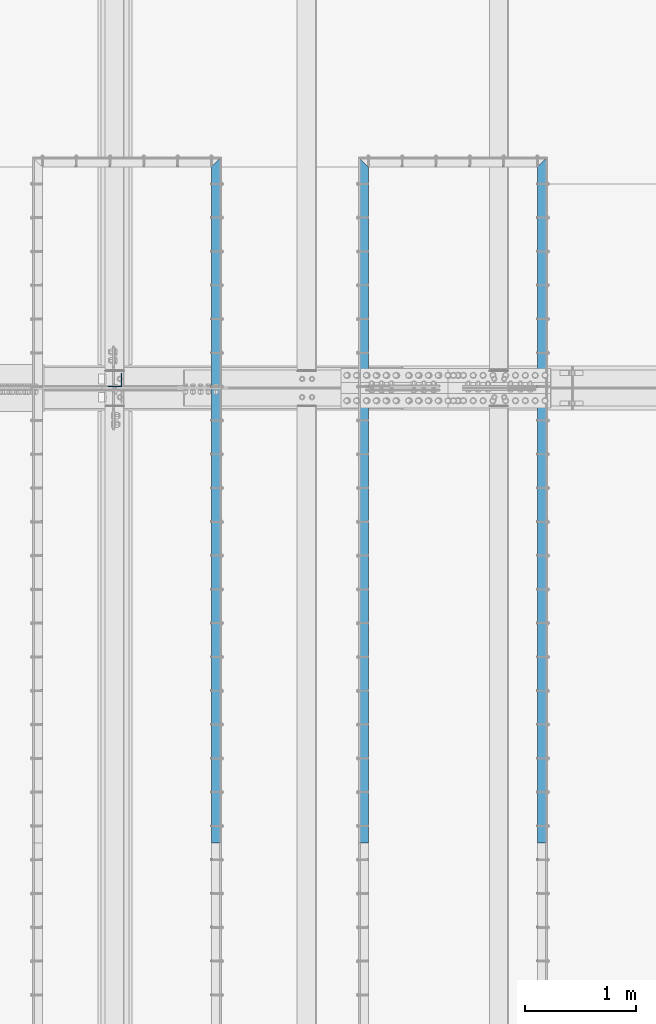
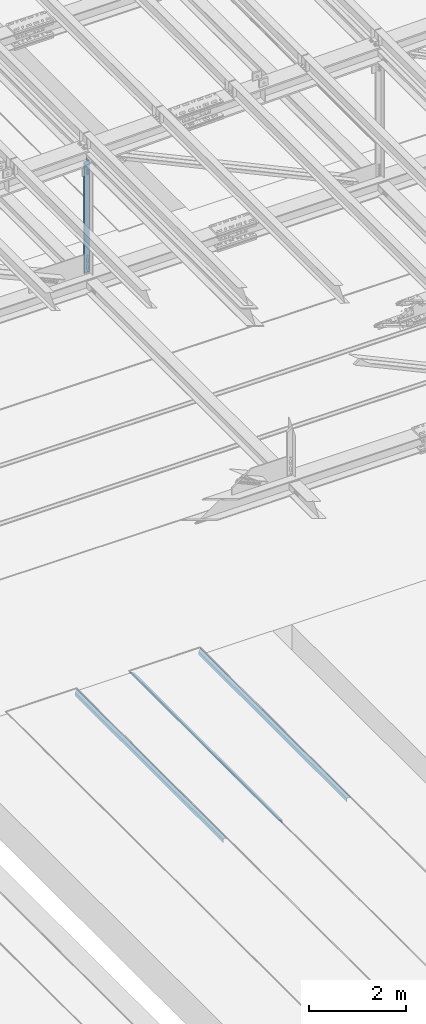
# One storey, part 1843 of 3843: 4 beams, 4 elements without a shape of their own.
"""IFC2X3 building model written with IfcOpenShell, lengths in millimetres."""

from ifc_helpers import new_model, si_unit, frame, origin_with_axes, place, context, subcontext, project, spatial, faceted_brep, material, type_object, element, aggregate, save


model = new_model("IFC2X3")

# Units and contexts
model_context = context("Model", 3, precision=1e-05, world=origin_with_axes())
body_context = subcontext(model_context, "Body", "Model", "MODEL_VIEW")
ifc_project = project(units=[si_unit("LENGTHUNIT", "METRE", prefix="MILLI"), si_unit("AREAUNIT", "SQUARE_METRE"), si_unit("VOLUMEUNIT", "CUBIC_METRE"), si_unit("MASSUNIT", "GRAM", prefix="KILO"), si_unit("TIMEUNIT", "SECOND"), si_unit("PLANEANGLEUNIT", "RADIAN"), si_unit("SOLIDANGLEUNIT", "STERADIAN"), si_unit("THERMODYNAMICTEMPERATUREUNIT", "DEGREE_CELSIUS"), si_unit("LUMINOUSINTENSITYUNIT", "LUMEN")], contexts=[model_context])

# Site, building, storey
site_placement = place(None, origin_with_axes())
site = spatial("IfcSite", under=ifc_project, at=site_placement, CompositionType="ELEMENT")
building_placement = place(site_placement, origin_with_axes())
building = spatial("IfcBuilding", under=site, at=building_placement, Name="Undefined", CompositionType="ELEMENT")
storey_placement = place(building_placement, origin_with_axes())
storey = spatial("IfcBuildingStorey", under=building, at=storey_placement, Name="Undefined", CompositionType="ELEMENT", Elevation=0.0)

# Assembly, beam
assembly_1_placement = place(storey_placement, origin_with_axes())
assembly_1 = element("IfcElementAssembly", 1, at=assembly_1_placement, inside=storey, Name="EMBED_ANGLE", AssemblyPlace="NOTDEFINED", PredefinedType="RIGID_FRAME")
ifc_material_1 = material(Name="STEEL/A36")
beam_type_1 = type_object("IfcBeamType", Name="L3-1/2X3-1/2X5/16", PredefinedType="NOTDEFINED")
beam_1_placement = place(assembly_1_placement, frame((52851.7485419922, 52641.499609375, 30410.15), z_axis=(0.0, 0.0, -1.0), x_axis=(0.0, -1.0, 0.0)))
beam_1 = element("IfcBeam", 2, at=beam_1_placement, type_object=beam_type_1, material=ifc_material_1, Name="EMBED_ANGLE", ObjectType="L3-1/2X3-1/2X5/16", context=body_context, shape_type="Brep", body=[
    faceted_brep([(88.9005548157729, 44.4499999999971, -44.4500000000007), (88.9005548157729, 44.4499999999971, 44.4500000000007), (6184.90000000001, 44.4499999999971, 44.4500000000007), (6184.90000000001, 44.4499999999971, -44.4500000000007), (80.9630575435294, 36.5124999999971, 44.4500000000007), (6184.90000000001, 36.5124999999971, 44.4500000000007), (80.9630575435294, 36.5124999999971, -36.5125000000007), (6184.90000000001, 36.5124999999971, -36.5125000000007), (0.00058536660799291, -44.4499999999971, -36.5125000000007), (6184.89999999999, -44.4499999999971, -36.5125000000007), (0.00058536660799291, -44.4499999999971, -44.4500000000007), (6184.89999999999, -44.4499999999971, -44.4500000000007)], [[[0, 1, 2, 3]], [[1, 4, 5, 2]], [[4, 6, 7, 5]], [[6, 8, 9, 7]], [[8, 10, 11, 9]], [[10, 0, 3, 11]], [[5, 7, 9, 11, 3, 2]], [[10, 8, 6, 4, 1, 0]]]),
])
aggregate(assembly_1, [beam_1])

assembly_2_placement = place(storey_placement, origin_with_axes())
assembly_2 = element("IfcElementAssembly", 3, at=assembly_2_placement, inside=storey, Name="EMBED_ANGLE", AssemblyPlace="NOTDEFINED", PredefinedType="RIGID_FRAME")
beam_2_placement = place(assembly_2_placement, frame((51238.911984375, 46456.599609375, 30410.15), z_axis=(0.0, 0.0, -1.0), x_axis=(0.0, 1.0, 0.0)))
beam_2 = element("IfcBeam", 4, at=beam_2_placement, type_object=beam_type_1, material=ifc_material_1, Name="EMBED_ANGLE", ObjectType="L3-1/2X3-1/2X5/16", context=body_context, shape_type="Brep", body=[
    faceted_brep([(-3.63797880709171e-12, 44.4499999999971, -44.4500000000007), (-3.63797880709171e-12, 44.4499999999971, 44.4500000000007), (6096.0, 44.4499999999971, 44.4500000000007), (6096.0, 44.4499999999971, -44.4500000000007), (-3.63797880709171e-12, 36.5124999999971, 44.4500000000007), (6103.9375, 36.5124999999971, 44.4500000000007), (-3.63797880709171e-12, 36.5124999999971, -36.5125000000007), (6103.9375, 36.5124999999971, -36.5125000000007), (3.63797880709171e-12, -44.4499999999971, -36.5125000000007), (6184.89999999999, -44.4499999999971, -36.5125000000007), (3.63797880709171e-12, -44.4499999999971, -44.4500000000007), (6184.89999999999, -44.4499999999971, -44.4500000000007)], [[[0, 1, 2, 3]], [[1, 4, 5, 2]], [[4, 6, 7, 5]], [[6, 8, 9, 7]], [[8, 10, 11, 9]], [[10, 0, 3, 11]], [[5, 7, 9, 11, 3, 2]], [[10, 8, 6, 4, 1, 0]]]),
])
aggregate(assembly_2, [beam_2])

assembly_3_placement = place(storey_placement, origin_with_axes())
assembly_3 = element("IfcElementAssembly", 5, at=assembly_3_placement, inside=storey, Name="EMBED_ANGLE", AssemblyPlace="NOTDEFINED", PredefinedType="RIGID_FRAME")
beam_3_placement = place(assembly_3_placement, frame((49911.7620881988, 52641.4996235989, 30410.15), z_axis=(0.0, 0.0, -1.0), x_axis=(0.0, -1.0, 0.0)))
beam_3 = element("IfcBeam", 6, at=beam_3_placement, type_object=beam_type_1, material=ifc_material_1, Name="EMBED_ANGLE", ObjectType="L3-1/2X3-1/2X5/16", context=body_context, shape_type="Brep", body=[
    faceted_brep([(88.8999999971129, 44.4500000000007, -44.4499999999971), (88.8999999965163, 44.4499999999971, 44.4500000000007), (6184.90000000001, 44.4499999999971, 44.4500000000007), (6184.90000000001, 44.4499999999971, -44.4500000000007), (80.9624999965163, 36.5124999999971, 44.4500000000007), (6184.90000000001, 36.5124999999971, 44.4500000000007), (80.9624999971129, 36.5125000000007, -36.5124999999971), (6184.90000000001, 36.5124999999971, -36.5125000000007), (3.63797880709171e-12, -44.4499999999971, -36.5125000000007), (6184.89999999999, -44.4499999999971, -36.5125000000007), (3.63797880709171e-12, -44.4499999999971, -44.4500000000007), (6184.89999999999, -44.4499999999971, -44.4500000000007)], [[[0, 1, 2, 3]], [[1, 4, 5, 2]], [[4, 6, 7, 5]], [[6, 8, 9, 7]], [[8, 10, 11, 9]], [[10, 0, 3, 11]], [[5, 7, 9, 11, 3, 2]], [[10, 8, 6, 4, 1, 0]]]),
])
aggregate(assembly_3, [beam_3])

assembly_4_placement = place(storey_placement, origin_with_axes())
assembly_4 = element("IfcElementAssembly", 7, at=assembly_4_placement, inside=storey, Name="ANGLE", AssemblyPlace="NOTDEFINED", PredefinedType="RIGID_FRAME")
ifc_material_2 = material(Name="STEEL/A572-50")
beam_type_2 = type_object("IfcBeamType", Name="L5X5X3/8", PredefinedType="NOTDEFINED")
beam_4_placement = place(assembly_4_placement, frame((48996.6, 50631.725, 45545.4054252378), z_axis=(-1.0, 0.0, 0.0), x_axis=(0.0, 0.0, -1.0)))
beam_4 = element("IfcBeam", 8, at=beam_4_placement, type_object=beam_type_2, material=ifc_material_2, Name="ANGLE", ObjectType="L5X5X3/8", context=body_context, shape_type="Brep", body=[
    faceted_brep([(223.33474071286, 63.5, -63.5), (223.33474071286, 63.5, 63.5), (3027.63868685271, 63.5, 63.5), (3027.63868685271, 63.5, -63.5), (223.33474071286, 53.9749999999985, 63.5), (3027.63868685271, 53.9749999999985, 63.5), (223.33474071286, 53.9749999999985, -53.9749999999985), (3027.63868685271, 53.9749999999985, -53.9749999999985), (223.33474071286, -63.5, -53.9749999999985), (3027.63868685271, -63.5, -53.9749999999985), (223.33474071286, -63.5, -63.5), (3027.63868685271, -63.5, -63.5)], [[[0, 1, 2, 3]], [[1, 4, 5, 2]], [[4, 6, 7, 5]], [[6, 8, 9, 7]], [[8, 10, 11, 9]], [[10, 0, 3, 11]], [[5, 7, 9, 11, 3, 2]], [[10, 8, 6, 4, 1, 0]]]),
])
aggregate(assembly_4, [beam_4])

save(model, "model.ifc")
